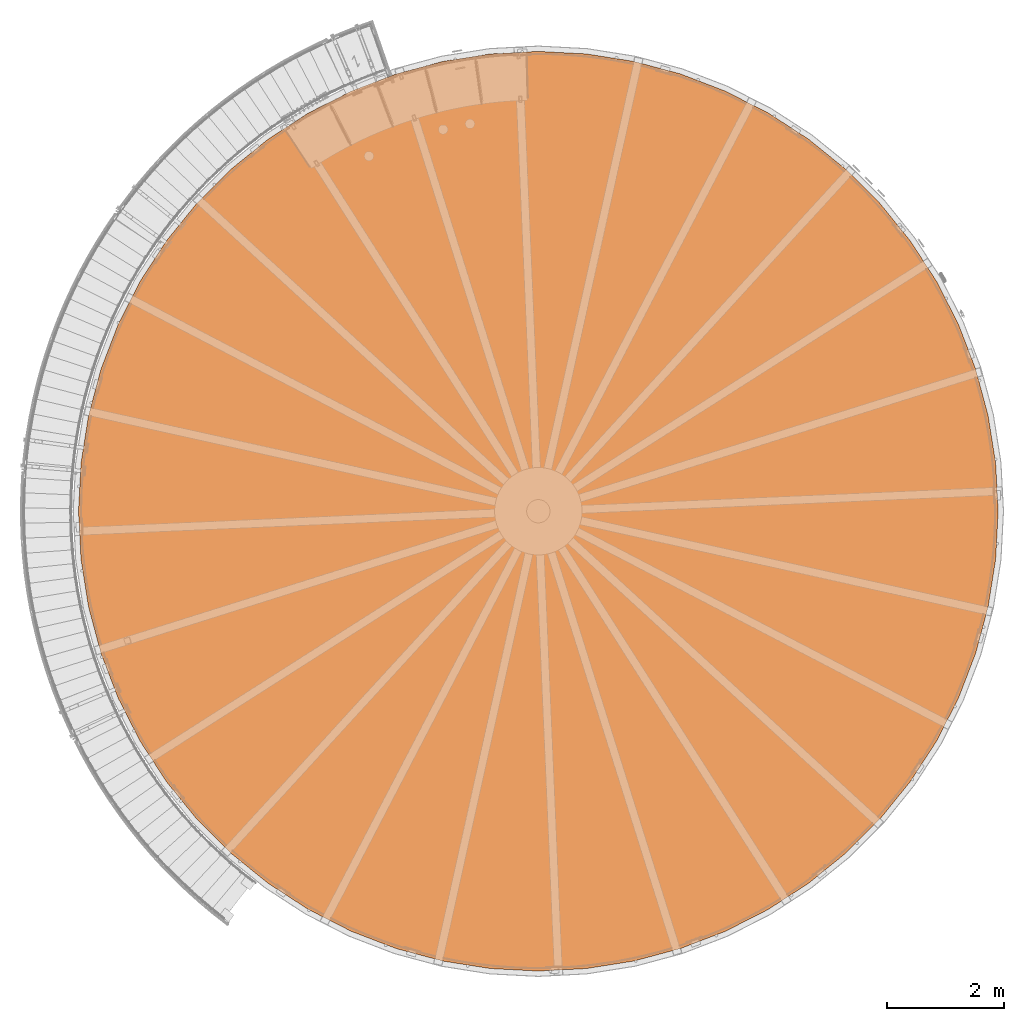
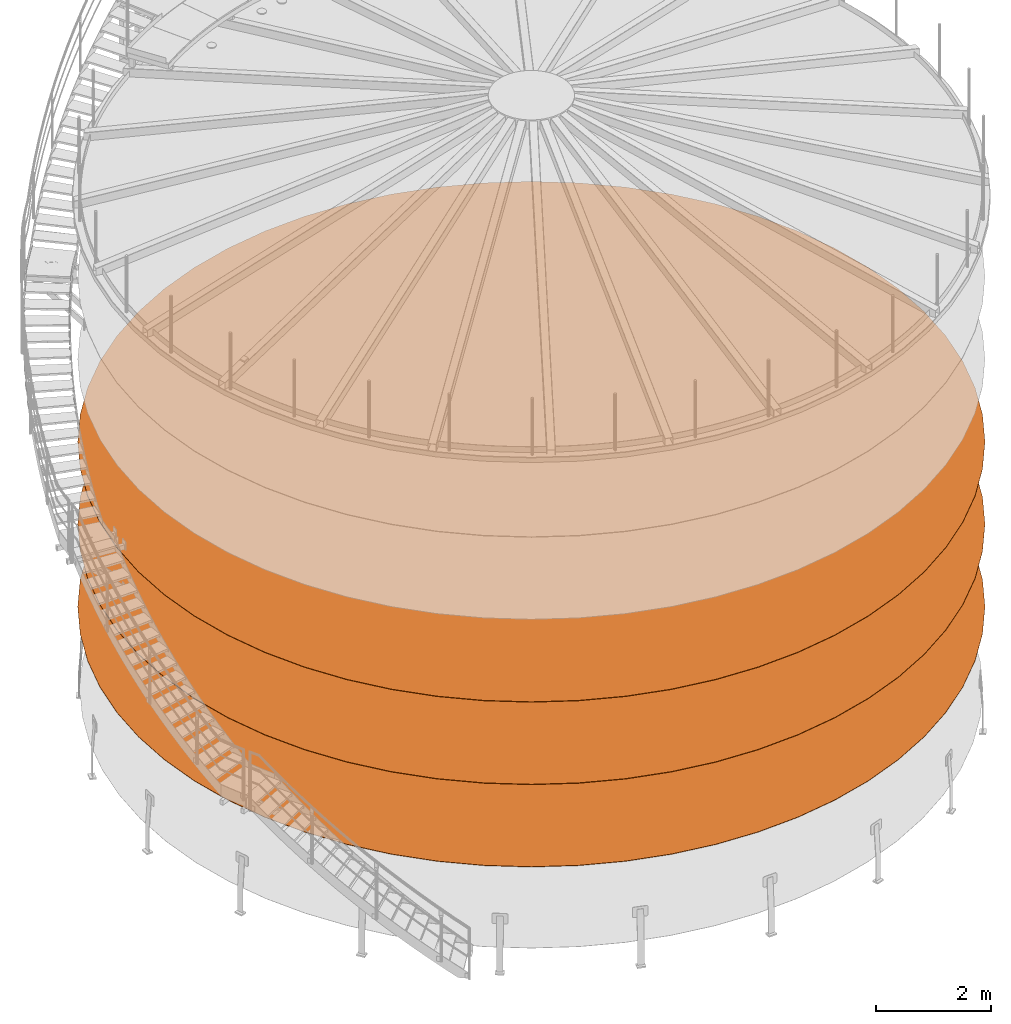
# One storey, part 20 of 126: 3 proxies.
"""IFC2X3 building model written with IfcOpenShell, lengths in millimetres."""

from ifc_helpers import new_model, si_unit, origin, origin_with_axes, place, context, project, spatial, faceted_brep, material, element, save


model = new_model("IFC2X3")

# Units and contexts
context_of_model_1 = context(None, 3, precision=0.1, world=origin())
context_of_model_2 = context(None, 3, precision=0.1, world=origin())
ifc_project = project(units=[si_unit("LENGTHUNIT", "METRE", prefix="MILLI"), si_unit("AREAUNIT", "SQUARE_METRE", prefix="CENTI"), si_unit("VOLUMEUNIT", "CUBIC_METRE", prefix="CENTI"), si_unit("MASSUNIT", "GRAM", prefix="KILO")], contexts=[context_of_model_1, context_of_model_2])

# Site, building, storey
site_placement = place(None, origin_with_axes())
site = spatial("IfcSite", under=ifc_project, at=site_placement, CompositionType="ELEMENT")
building_placement = place(site_placement, origin_with_axes())
building = spatial("IfcBuilding", under=site, at=building_placement, CompositionType="ELEMENT")
storey_placement = place(building_placement, origin_with_axes())
storey = spatial("IfcBuildingStorey", under=building, at=storey_placement, CompositionType="ELEMENT")

# Proxies
ifc_material = material(Name="STAHL")
proxy_1_placement = place(storey_placement, origin_with_axes())
element("IfcBuildingElementProxy", 1, at=proxy_1_placement, inside=storey, material=ifc_material, Name="profile", context=context_of_model_2, shape_type="Brep", body=[
    faceted_brep([(4062.5, 14833.6, 5256.0), (4797.9, 15208.3, 5256.0), (4797.9, 15208.3, 5248.0), (4062.5, 14833.6, 5248.0), (15890.0, 8005.0, 5256.0), (15890.0, 8005.0, 5248.0), (15846.8, 8829.2, 5248.0), (15846.8, 8829.2, 5256.0), (3370.3, 14384.1, 5256.0), (3370.3, 14384.1, 5248.0), (15717.7, 9644.4, 5248.0), (15717.7, 9644.4, 5256.0), (2728.9, 13864.7, 5256.0), (2728.9, 13864.7, 5248.0), (2145.3, 13281.1, 5256.0), (2145.3, 13281.1, 5248.0), (15504.1, 10441.6, 5256.0), (15504.1, 10441.6, 5248.0), (1625.9, 12639.7, 5256.0), (1625.9, 12639.7, 5248.0), (15208.3, 11212.1, 5256.0), (15208.3, 11212.1, 5248.0), (1176.4, 11947.5, 5256.0), (1176.4, 11947.5, 5248.0), (14833.6, 11947.5, 5256.0), (14833.6, 11947.5, 5248.0), (801.7, 11212.1, 5256.0), (801.7, 11212.1, 5248.0), (14384.1, 12639.7, 5256.0), (14384.1, 12639.7, 5248.0), (505.9, 10441.6, 5256.0), (505.9, 10441.6, 5248.0), (13864.7, 13281.1, 5256.0), (13864.7, 13281.1, 5248.0), (292.3, 9644.4, 5256.0), (292.3, 9644.4, 5248.0), (13281.1, 13864.7, 5256.0), (13281.1, 13864.7, 5248.0), (163.2, 8829.2, 5256.0), (163.2, 8829.2, 5248.0), (12639.7, 14384.1, 5256.0), (12639.7, 14384.1, 5248.0), (120.0, 8005.0, 5256.0), (120.0, 8005.0, 5248.0), (11947.5, 14833.6, 5256.0), (11947.5, 14833.6, 5248.0), (11212.1, 15208.3, 5256.0), (11212.1, 15208.3, 5248.0), (10441.6, 15504.1, 5256.0), (10441.6, 15504.1, 5248.0), (9644.4, 15717.7, 5256.0), (9644.4, 15717.7, 5248.0), (8829.2, 15846.8, 5256.0), (8829.2, 15846.8, 5248.0), (8005.0, 15890.0, 5256.0), (8005.0, 15890.0, 5248.0), (7180.8, 15846.8, 5256.0), (7180.8, 15846.8, 5248.0), (6365.6, 15717.7, 5256.0), (6365.6, 15717.7, 5248.0), (5568.4, 15504.1, 5256.0), (5568.4, 15504.1, 5248.0), (11179.6, 874.8, 5256.0), (11179.6, 874.8, 5248.0), (10416.9, 582.0, 5248.0), (10416.9, 582.0, 5256.0), (11907.5, 1245.7, 5256.0), (11907.5, 1245.7, 5248.0), (200.0, 8005.0, 5256.0), (242.8, 7189.2, 5256.0), (242.8, 7189.2, 5248.0), (200.0, 8005.0, 5248.0), (12592.7, 1690.6, 5256.0), (12592.7, 1690.6, 5248.0), (13227.6, 2204.8, 5256.0), (13227.6, 2204.8, 5248.0), (370.6, 6382.2, 5256.0), (370.6, 6382.2, 5248.0), (13805.2, 2782.4, 5256.0), (13805.2, 2782.4, 5248.0), (582.0, 5593.1, 5256.0), (582.0, 5593.1, 5248.0), (14319.4, 3417.3, 5256.0), (14319.4, 3417.3, 5248.0), (874.8, 4830.4, 5256.0), (874.8, 4830.4, 5248.0), (14764.3, 4102.5, 5256.0), (14764.3, 4102.5, 5248.0), (1245.7, 4102.5, 5256.0), (1245.7, 4102.5, 5248.0), (15135.2, 4830.4, 5256.0), (15135.2, 4830.4, 5248.0), (1690.6, 3417.3, 5256.0), (1690.6, 3417.3, 5248.0), (15428.0, 5593.1, 5256.0), (15428.0, 5593.1, 5248.0), (2204.8, 2782.4, 5256.0), (2204.8, 2782.4, 5248.0), (15639.4, 6382.2, 5256.0), (15639.4, 6382.2, 5248.0), (2782.4, 2204.8, 5256.0), (2782.4, 2204.8, 5248.0), (15767.2, 7189.2, 5256.0), (15767.2, 7189.2, 5248.0), (3417.3, 1690.6, 5256.0), (3417.3, 1690.6, 5248.0), (15810.0, 8005.0, 5256.0), (15810.0, 8005.0, 5248.0), (4102.5, 1245.7, 5256.0), (4102.5, 1245.7, 5248.0), (4830.4, 874.8, 5256.0), (4830.4, 874.8, 5248.0), (5593.1, 582.0, 5256.0), (5593.1, 582.0, 5248.0), (6382.2, 370.6, 5256.0), (6382.2, 370.6, 5248.0), (7189.2, 242.8, 5256.0), (7189.2, 242.8, 5248.0), (8005.0, 200.0, 5256.0), (8005.0, 200.0, 5248.0), (8820.8, 242.8, 5256.0), (8820.8, 242.8, 5248.0), (9627.8, 370.6, 5256.0), (9627.8, 370.6, 5248.0), (8005.0, 120.0, 5256.0), (8829.2, 163.2, 5256.0), (9644.4, 292.3, 5256.0), (10441.6, 505.9, 5256.0), (11212.1, 801.7, 5256.0), (11947.5, 1176.4, 5256.0), (12639.7, 1625.9, 5256.0), (13281.1, 2145.3, 5256.0), (13864.7, 2728.9, 5256.0), (14384.1, 3370.3, 5256.0), (14833.6, 4062.5, 5256.0), (15208.3, 4797.9, 5256.0), (15504.1, 5568.4, 5256.0), (15717.7, 6365.6, 5256.0), (15846.8, 7180.8, 5256.0), (163.2, 7180.8, 5256.0), (292.3, 6365.6, 5256.0), (505.9, 5568.4, 5256.0), (801.7, 4797.9, 5256.0), (1176.4, 4062.5, 5256.0), (1625.9, 3370.3, 5256.0), (2145.3, 2728.9, 5256.0), (2728.9, 2145.3, 5256.0), (242.8, 8820.8, 5256.0), (370.6, 9627.8, 5256.0), (582.0, 10416.9, 5256.0), (874.8, 11179.6, 5256.0), (1245.7, 11907.5, 5256.0), (1690.6, 12592.7, 5256.0), (2204.8, 13227.6, 5256.0), (2782.4, 13805.2, 5256.0), (3417.3, 14319.4, 5256.0), (4102.5, 14764.3, 5256.0), (4830.4, 15135.2, 5256.0), (5593.1, 15428.0, 5256.0), (6382.2, 15639.4, 5256.0), (7189.2, 15767.2, 5256.0), (8005.0, 15810.0, 5256.0), (8820.8, 15767.2, 5256.0), (9627.8, 15639.4, 5256.0), (10416.9, 15428.0, 5256.0), (11179.6, 15135.2, 5256.0), (11907.5, 14764.3, 5256.0), (12592.7, 14319.4, 5256.0), (13227.6, 13805.2, 5256.0), (13805.2, 13227.6, 5256.0), (14319.4, 12592.7, 5256.0), (14764.3, 11907.5, 5256.0), (15135.2, 11179.6, 5256.0), (15428.0, 10416.9, 5256.0), (15639.4, 9627.8, 5256.0), (15767.2, 8820.8, 5256.0), (3370.3, 1625.9, 5256.0), (4062.5, 1176.4, 5256.0), (4797.9, 801.7, 5256.0), (5568.4, 505.9, 5256.0), (6365.6, 292.3, 5256.0), (7180.8, 163.2, 5256.0), (4830.4, 15135.2, 5248.0), (5593.1, 15428.0, 5248.0), (4102.5, 14764.3, 5248.0), (3417.3, 14319.4, 5248.0), (15767.2, 8820.8, 5248.0), (2782.4, 13805.2, 5248.0), (15639.4, 9627.8, 5248.0), (2204.8, 13227.6, 5248.0), (15428.0, 10416.9, 5248.0), (1690.6, 12592.7, 5248.0), (15135.2, 11179.6, 5248.0), (1245.7, 11907.5, 5248.0), (14764.3, 11907.5, 5248.0), (874.8, 11179.6, 5248.0), (14319.4, 12592.7, 5248.0), (582.0, 10416.9, 5248.0), (13805.2, 13227.6, 5248.0), (370.6, 9627.8, 5248.0), (13227.6, 13805.2, 5248.0), (242.8, 8820.8, 5248.0), (12592.7, 14319.4, 5248.0), (11907.5, 14764.3, 5248.0), (11179.6, 15135.2, 5248.0), (10416.9, 15428.0, 5248.0), (9627.8, 15639.4, 5248.0), (8820.8, 15767.2, 5248.0), (8005.0, 15810.0, 5248.0), (7189.2, 15767.2, 5248.0), (6382.2, 15639.4, 5248.0), (8005.0, 120.0, 5248.0), (7180.8, 163.2, 5248.0), (6365.6, 292.3, 5248.0), (5568.4, 505.9, 5248.0), (4797.9, 801.7, 5248.0), (4062.5, 1176.4, 5248.0), (3370.3, 1625.9, 5248.0), (2728.9, 2145.3, 5248.0), (2145.3, 2728.9, 5248.0), (1625.9, 3370.3, 5248.0), (1176.4, 4062.5, 5248.0), (801.7, 4797.9, 5248.0), (505.9, 5568.4, 5248.0), (292.3, 6365.6, 5248.0), (163.2, 7180.8, 5248.0), (15846.8, 7180.8, 5248.0), (15717.7, 6365.6, 5248.0), (15504.1, 5568.4, 5248.0), (15208.3, 4797.9, 5248.0), (14833.6, 4062.5, 5248.0), (14384.1, 3370.3, 5248.0), (13864.7, 2728.9, 5248.0), (13281.1, 2145.3, 5248.0), (12639.7, 1625.9, 5248.0), (11947.5, 1176.4, 5248.0), (11212.1, 801.7, 5248.0), (10441.6, 505.9, 5248.0), (9644.4, 292.3, 5248.0), (8829.2, 163.2, 5248.0)], [[[0, 1, 2, 3]], [[4, 5, 6, 7]], [[8, 0, 3, 9]], [[7, 6, 10, 11]], [[12, 8, 9, 13]], [[14, 12, 13, 15]], [[16, 11, 10, 17]], [[18, 14, 15, 19]], [[20, 16, 17, 21]], [[22, 18, 19, 23]], [[24, 20, 21, 25]], [[26, 22, 23, 27]], [[28, 24, 25, 29]], [[30, 26, 27, 31]], [[32, 28, 29, 33]], [[34, 30, 31, 35]], [[36, 32, 33, 37]], [[38, 34, 35, 39]], [[40, 36, 37, 41]], [[42, 38, 39, 43]], [[44, 40, 41, 45]], [[46, 44, 45, 47]], [[48, 46, 47, 49]], [[50, 48, 49, 51]], [[52, 50, 51, 53]], [[54, 52, 53, 55]], [[56, 54, 55, 57]], [[58, 56, 57, 59]], [[60, 58, 59, 61]], [[1, 60, 61, 2]], [[62, 63, 64, 65]], [[66, 67, 63, 62]], [[68, 69, 70, 71]], [[72, 73, 67, 66]], [[74, 75, 73, 72]], [[76, 77, 70, 69]], [[78, 79, 75, 74]], [[80, 81, 77, 76]], [[82, 83, 79, 78]], [[84, 85, 81, 80]], [[86, 87, 83, 82]], [[88, 89, 85, 84]], [[90, 91, 87, 86]], [[92, 93, 89, 88]], [[94, 95, 91, 90]], [[96, 97, 93, 92]], [[98, 99, 95, 94]], [[100, 101, 97, 96]], [[102, 103, 99, 98]], [[104, 105, 101, 100]], [[106, 107, 103, 102]], [[108, 109, 105, 104]], [[110, 111, 109, 108]], [[112, 113, 111, 110]], [[114, 115, 113, 112]], [[116, 117, 115, 114]], [[118, 119, 117, 116]], [[120, 121, 119, 118]], [[122, 123, 121, 120]], [[65, 64, 123, 122]], [[124, 125, 126, 127, 128, 129, 130, 131, 132, 133, 134, 135, 136, 137, 138, 4, 7, 11, 16, 20, 24, 28, 32, 36, 40, 44, 46, 48, 50, 52, 54, 56, 58, 60, 1, 0, 8, 12, 14, 18, 22, 26, 30, 34, 38, 42, 139, 140, 141, 142, 143, 144, 145, 146, 96, 92, 88, 84, 80, 76, 69, 68, 147, 148, 149, 150, 151, 152, 153, 154, 155, 156, 157, 158, 159, 160, 161, 162, 163, 164, 165, 166, 167, 168, 169, 170, 171, 172, 173, 174, 175, 106, 102, 98, 94, 90, 86, 82, 78, 74, 72, 66, 62, 65, 122, 120, 118, 116, 114, 112, 110, 108, 104, 100, 96, 146, 176, 177, 178, 179, 180, 181]], [[157, 182, 183, 158]], [[156, 184, 182, 157]], [[155, 185, 184, 156]], [[175, 186, 107, 106]], [[154, 187, 185, 155]], [[174, 188, 186, 175]], [[153, 189, 187, 154]], [[173, 190, 188, 174]], [[152, 191, 189, 153]], [[172, 192, 190, 173]], [[151, 193, 191, 152]], [[171, 194, 192, 172]], [[150, 195, 193, 151]], [[170, 196, 194, 171]], [[149, 197, 195, 150]], [[169, 198, 196, 170]], [[148, 199, 197, 149]], [[168, 200, 198, 169]], [[147, 201, 199, 148]], [[167, 202, 200, 168]], [[68, 71, 201, 147]], [[166, 203, 202, 167]], [[165, 204, 203, 166]], [[164, 205, 204, 165]], [[163, 206, 205, 164]], [[162, 207, 206, 163]], [[161, 208, 207, 162]], [[160, 209, 208, 161]], [[159, 210, 209, 160]], [[158, 183, 210, 159]], [[211, 212, 213, 214, 215, 216, 217, 218, 219, 220, 221, 222, 223, 224, 225, 43, 39, 35, 31, 27, 23, 19, 15, 13, 9, 3, 2, 61, 59, 57, 55, 53, 51, 49, 47, 45, 41, 37, 33, 29, 25, 21, 17, 10, 6, 5, 226, 227, 228, 229, 230, 231, 232, 75, 79, 83, 87, 91, 95, 99, 103, 107, 186, 188, 190, 192, 194, 196, 198, 200, 202, 203, 204, 205, 206, 207, 208, 209, 210, 183, 182, 184, 185, 187, 189, 191, 193, 195, 197, 199, 201, 71, 70, 77, 81, 85, 89, 93, 97, 101, 105, 109, 111, 113, 115, 117, 119, 121, 123, 64, 63, 67, 73, 75, 232, 233, 234, 235, 236, 237, 238, 239]], [[128, 127, 237, 236]], [[129, 128, 236, 235]], [[130, 129, 235, 234]], [[139, 42, 43, 225]], [[131, 130, 234, 233]], [[140, 139, 225, 224]], [[140, 224, 223, 141]], [[132, 131, 233, 232]], [[133, 132, 232, 231]], [[142, 141, 223, 222]], [[134, 133, 231, 230]], [[143, 142, 222, 221]], [[135, 134, 230, 229]], [[144, 143, 221, 220]], [[136, 135, 229, 228]], [[145, 144, 220, 219]], [[137, 136, 228, 227]], [[146, 145, 219, 218]], [[138, 137, 227, 226]], [[176, 146, 218, 217]], [[4, 138, 226, 5]], [[177, 176, 217, 216]], [[178, 177, 216, 215]], [[179, 178, 215, 214]], [[180, 179, 214, 213]], [[181, 180, 213, 212]], [[124, 181, 212, 211]], [[125, 124, 211, 239]], [[126, 125, 239, 238]], [[127, 126, 238, 237]]]),
])
proxy_2_placement = place(storey_placement, origin_with_axes())
element("IfcBuildingElementProxy", 2, at=proxy_2_placement, inside=storey, material=ifc_material, Name="profile", context=context_of_model_2, shape_type="Brep", body=[
    faceted_brep([(4062.5, 14833.6, 3506.0), (4797.9, 15208.3, 3506.0), (4797.9, 15208.3, 3498.0), (4062.5, 14833.6, 3498.0), (15890.0, 8005.0, 3506.0), (15890.0, 8005.0, 3498.0), (15846.8, 8829.2, 3498.0), (15846.8, 8829.2, 3506.0), (3370.3, 14384.1, 3506.0), (3370.3, 14384.1, 3498.0), (15717.7, 9644.4, 3498.0), (15717.7, 9644.4, 3506.0), (2728.9, 13864.7, 3506.0), (2728.9, 13864.7, 3498.0), (2145.3, 13281.1, 3506.0), (2145.3, 13281.1, 3498.0), (15504.1, 10441.6, 3506.0), (15504.1, 10441.6, 3498.0), (1625.9, 12639.7, 3506.0), (1625.9, 12639.7, 3498.0), (15208.3, 11212.1, 3506.0), (15208.3, 11212.1, 3498.0), (1176.4, 11947.5, 3506.0), (1176.4, 11947.5, 3498.0), (14833.6, 11947.5, 3506.0), (14833.6, 11947.5, 3498.0), (801.7, 11212.1, 3506.0), (801.7, 11212.1, 3498.0), (14384.1, 12639.7, 3506.0), (14384.1, 12639.7, 3498.0), (505.9, 10441.6, 3506.0), (505.9, 10441.6, 3498.0), (13864.7, 13281.1, 3506.0), (13864.7, 13281.1, 3498.0), (292.3, 9644.4, 3506.0), (292.3, 9644.4, 3498.0), (13281.1, 13864.7, 3506.0), (13281.1, 13864.7, 3498.0), (163.2, 8829.2, 3506.0), (163.2, 8829.2, 3498.0), (12639.7, 14384.1, 3506.0), (12639.7, 14384.1, 3498.0), (120.0, 8005.0, 3506.0), (120.0, 8005.0, 3498.0), (11947.5, 14833.6, 3506.0), (11947.5, 14833.6, 3498.0), (11212.1, 15208.3, 3506.0), (11212.1, 15208.3, 3498.0), (10441.6, 15504.1, 3506.0), (10441.6, 15504.1, 3498.0), (9644.4, 15717.7, 3506.0), (9644.4, 15717.7, 3498.0), (8829.2, 15846.8, 3506.0), (8829.2, 15846.8, 3498.0), (8005.0, 15890.0, 3506.0), (8005.0, 15890.0, 3498.0), (7180.8, 15846.8, 3506.0), (7180.8, 15846.8, 3498.0), (6365.6, 15717.7, 3506.0), (6365.6, 15717.7, 3498.0), (5568.4, 15504.1, 3506.0), (5568.4, 15504.1, 3498.0), (11179.6, 874.8, 3506.0), (11179.6, 874.8, 3498.0), (10416.9, 582.0, 3498.0), (10416.9, 582.0, 3506.0), (11907.5, 1245.7, 3506.0), (11907.5, 1245.7, 3498.0), (200.0, 8005.0, 3506.0), (242.8, 7189.2, 3506.0), (242.8, 7189.2, 3498.0), (200.0, 8005.0, 3498.0), (12592.7, 1690.6, 3506.0), (12592.7, 1690.6, 3498.0), (13227.6, 2204.8, 3506.0), (13227.6, 2204.8, 3498.0), (370.6, 6382.2, 3506.0), (370.6, 6382.2, 3498.0), (13805.2, 2782.4, 3506.0), (13805.2, 2782.4, 3498.0), (582.0, 5593.1, 3506.0), (582.0, 5593.1, 3498.0), (14319.4, 3417.3, 3506.0), (14319.4, 3417.3, 3498.0), (874.8, 4830.4, 3506.0), (874.8, 4830.4, 3498.0), (14764.3, 4102.5, 3506.0), (14764.3, 4102.5, 3498.0), (1245.7, 4102.5, 3506.0), (1245.7, 4102.5, 3498.0), (15135.2, 4830.4, 3506.0), (15135.2, 4830.4, 3498.0), (1690.6, 3417.3, 3506.0), (1690.6, 3417.3, 3498.0), (15428.0, 5593.1, 3506.0), (15428.0, 5593.1, 3498.0), (2204.8, 2782.4, 3506.0), (2204.8, 2782.4, 3498.0), (15639.4, 6382.2, 3506.0), (15639.4, 6382.2, 3498.0), (2782.4, 2204.8, 3506.0), (2782.4, 2204.8, 3498.0), (15767.2, 7189.2, 3506.0), (15767.2, 7189.2, 3498.0), (3417.3, 1690.6, 3506.0), (3417.3, 1690.6, 3498.0), (15810.0, 8005.0, 3506.0), (15810.0, 8005.0, 3498.0), (4102.5, 1245.7, 3506.0), (4102.5, 1245.7, 3498.0), (4830.4, 874.8, 3506.0), (4830.4, 874.8, 3498.0), (5593.1, 582.0, 3506.0), (5593.1, 582.0, 3498.0), (6382.2, 370.6, 3506.0), (6382.2, 370.6, 3498.0), (7189.2, 242.8, 3506.0), (7189.2, 242.8, 3498.0), (8005.0, 200.0, 3506.0), (8005.0, 200.0, 3498.0), (8820.8, 242.8, 3506.0), (8820.8, 242.8, 3498.0), (9627.8, 370.6, 3506.0), (9627.8, 370.6, 3498.0), (8005.0, 120.0, 3506.0), (8829.2, 163.2, 3506.0), (9644.4, 292.3, 3506.0), (10441.6, 505.9, 3506.0), (11212.1, 801.7, 3506.0), (11947.5, 1176.4, 3506.0), (12639.7, 1625.9, 3506.0), (13281.1, 2145.3, 3506.0), (13864.7, 2728.9, 3506.0), (14384.1, 3370.3, 3506.0), (14833.6, 4062.5, 3506.0), (15208.3, 4797.9, 3506.0), (15504.1, 5568.4, 3506.0), (15717.7, 6365.6, 3506.0), (15846.8, 7180.8, 3506.0), (163.2, 7180.8, 3506.0), (292.3, 6365.6, 3506.0), (505.9, 5568.4, 3506.0), (801.7, 4797.9, 3506.0), (1176.4, 4062.5, 3506.0), (1625.9, 3370.3, 3506.0), (2145.3, 2728.9, 3506.0), (2728.9, 2145.3, 3506.0), (242.8, 8820.8, 3506.0), (370.6, 9627.8, 3506.0), (582.0, 10416.9, 3506.0), (874.8, 11179.6, 3506.0), (1245.7, 11907.5, 3506.0), (1690.6, 12592.7, 3506.0), (2204.8, 13227.6, 3506.0), (2782.4, 13805.2, 3506.0), (3417.3, 14319.4, 3506.0), (4102.5, 14764.3, 3506.0), (4830.4, 15135.2, 3506.0), (5593.1, 15428.0, 3506.0), (6382.2, 15639.4, 3506.0), (7189.2, 15767.2, 3506.0), (8005.0, 15810.0, 3506.0), (8820.8, 15767.2, 3506.0), (9627.8, 15639.4, 3506.0), (10416.9, 15428.0, 3506.0), (11179.6, 15135.2, 3506.0), (11907.5, 14764.3, 3506.0), (12592.7, 14319.4, 3506.0), (13227.6, 13805.2, 3506.0), (13805.2, 13227.6, 3506.0), (14319.4, 12592.7, 3506.0), (14764.3, 11907.5, 3506.0), (15135.2, 11179.6, 3506.0), (15428.0, 10416.9, 3506.0), (15639.4, 9627.8, 3506.0), (15767.2, 8820.8, 3506.0), (3370.3, 1625.9, 3506.0), (4062.5, 1176.4, 3506.0), (4797.9, 801.7, 3506.0), (5568.4, 505.9, 3506.0), (6365.6, 292.3, 3506.0), (7180.8, 163.2, 3506.0), (4830.4, 15135.2, 3498.0), (5593.1, 15428.0, 3498.0), (4102.5, 14764.3, 3498.0), (3417.3, 14319.4, 3498.0), (15767.2, 8820.8, 3498.0), (2782.4, 13805.2, 3498.0), (15639.4, 9627.8, 3498.0), (2204.8, 13227.6, 3498.0), (15428.0, 10416.9, 3498.0), (1690.6, 12592.7, 3498.0), (15135.2, 11179.6, 3498.0), (1245.7, 11907.5, 3498.0), (14764.3, 11907.5, 3498.0), (874.8, 11179.6, 3498.0), (14319.4, 12592.7, 3498.0), (582.0, 10416.9, 3498.0), (13805.2, 13227.6, 3498.0), (370.6, 9627.8, 3498.0), (13227.6, 13805.2, 3498.0), (242.8, 8820.8, 3498.0), (12592.7, 14319.4, 3498.0), (11907.5, 14764.3, 3498.0), (11179.6, 15135.2, 3498.0), (10416.9, 15428.0, 3498.0), (9627.8, 15639.4, 3498.0), (8820.8, 15767.2, 3498.0), (8005.0, 15810.0, 3498.0), (7189.2, 15767.2, 3498.0), (6382.2, 15639.4, 3498.0), (8005.0, 120.0, 3498.0), (7180.8, 163.2, 3498.0), (6365.6, 292.3, 3498.0), (5568.4, 505.9, 3498.0), (4797.9, 801.7, 3498.0), (4062.5, 1176.4, 3498.0), (3370.3, 1625.9, 3498.0), (2728.9, 2145.3, 3498.0), (2145.3, 2728.9, 3498.0), (1625.9, 3370.3, 3498.0), (1176.4, 4062.5, 3498.0), (801.7, 4797.9, 3498.0), (505.9, 5568.4, 3498.0), (292.3, 6365.6, 3498.0), (163.2, 7180.8, 3498.0), (15846.8, 7180.8, 3498.0), (15717.7, 6365.6, 3498.0), (15504.1, 5568.4, 3498.0), (15208.3, 4797.9, 3498.0), (14833.6, 4062.5, 3498.0), (14384.1, 3370.3, 3498.0), (13864.7, 2728.9, 3498.0), (13281.1, 2145.3, 3498.0), (12639.7, 1625.9, 3498.0), (11947.5, 1176.4, 3498.0), (11212.1, 801.7, 3498.0), (10441.6, 505.9, 3498.0), (9644.4, 292.3, 3498.0), (8829.2, 163.2, 3498.0)], [[[0, 1, 2, 3]], [[4, 5, 6, 7]], [[8, 0, 3, 9]], [[7, 6, 10, 11]], [[12, 8, 9, 13]], [[14, 12, 13, 15]], [[16, 11, 10, 17]], [[18, 14, 15, 19]], [[20, 16, 17, 21]], [[22, 18, 19, 23]], [[24, 20, 21, 25]], [[26, 22, 23, 27]], [[28, 24, 25, 29]], [[30, 26, 27, 31]], [[32, 28, 29, 33]], [[34, 30, 31, 35]], [[36, 32, 33, 37]], [[38, 34, 35, 39]], [[40, 36, 37, 41]], [[42, 38, 39, 43]], [[44, 40, 41, 45]], [[46, 44, 45, 47]], [[48, 46, 47, 49]], [[50, 48, 49, 51]], [[52, 50, 51, 53]], [[54, 52, 53, 55]], [[56, 54, 55, 57]], [[58, 56, 57, 59]], [[60, 58, 59, 61]], [[1, 60, 61, 2]], [[62, 63, 64, 65]], [[66, 67, 63, 62]], [[68, 69, 70, 71]], [[72, 73, 67, 66]], [[74, 75, 73, 72]], [[76, 77, 70, 69]], [[78, 79, 75, 74]], [[80, 81, 77, 76]], [[82, 83, 79, 78]], [[84, 85, 81, 80]], [[86, 87, 83, 82]], [[88, 89, 85, 84]], [[90, 91, 87, 86]], [[92, 93, 89, 88]], [[94, 95, 91, 90]], [[96, 97, 93, 92]], [[98, 99, 95, 94]], [[100, 101, 97, 96]], [[102, 103, 99, 98]], [[104, 105, 101, 100]], [[106, 107, 103, 102]], [[108, 109, 105, 104]], [[110, 111, 109, 108]], [[112, 113, 111, 110]], [[114, 115, 113, 112]], [[116, 117, 115, 114]], [[118, 119, 117, 116]], [[120, 121, 119, 118]], [[122, 123, 121, 120]], [[65, 64, 123, 122]], [[124, 125, 126, 127, 128, 129, 130, 131, 132, 133, 134, 135, 136, 137, 138, 4, 7, 11, 16, 20, 24, 28, 32, 36, 40, 44, 46, 48, 50, 52, 54, 56, 58, 60, 1, 0, 8, 12, 14, 18, 22, 26, 30, 34, 38, 42, 139, 140, 141, 142, 143, 144, 145, 146, 96, 92, 88, 84, 80, 76, 69, 68, 147, 148, 149, 150, 151, 152, 153, 154, 155, 156, 157, 158, 159, 160, 161, 162, 163, 164, 165, 166, 167, 168, 169, 170, 171, 172, 173, 174, 175, 106, 102, 98, 94, 90, 86, 82, 78, 74, 72, 66, 62, 65, 122, 120, 118, 116, 114, 112, 110, 108, 104, 100, 96, 146, 176, 177, 178, 179, 180, 181]], [[157, 182, 183, 158]], [[156, 184, 182, 157]], [[155, 185, 184, 156]], [[175, 186, 107, 106]], [[154, 187, 185, 155]], [[174, 188, 186, 175]], [[153, 189, 187, 154]], [[173, 190, 188, 174]], [[152, 191, 189, 153]], [[172, 192, 190, 173]], [[151, 193, 191, 152]], [[171, 194, 192, 172]], [[150, 195, 193, 151]], [[170, 196, 194, 171]], [[149, 197, 195, 150]], [[169, 198, 196, 170]], [[148, 199, 197, 149]], [[168, 200, 198, 169]], [[147, 201, 199, 148]], [[167, 202, 200, 168]], [[68, 71, 201, 147]], [[166, 203, 202, 167]], [[165, 204, 203, 166]], [[164, 205, 204, 165]], [[163, 206, 205, 164]], [[162, 207, 206, 163]], [[161, 208, 207, 162]], [[160, 209, 208, 161]], [[159, 210, 209, 160]], [[158, 183, 210, 159]], [[211, 212, 213, 214, 215, 216, 217, 218, 219, 220, 221, 222, 223, 224, 225, 43, 39, 35, 31, 27, 23, 19, 15, 13, 9, 3, 2, 61, 59, 57, 55, 53, 51, 49, 47, 45, 41, 37, 33, 29, 25, 21, 17, 10, 6, 5, 226, 227, 228, 229, 230, 231, 232, 75, 79, 83, 87, 91, 95, 99, 103, 107, 186, 188, 190, 192, 194, 196, 198, 200, 202, 203, 204, 205, 206, 207, 208, 209, 210, 183, 182, 184, 185, 187, 189, 191, 193, 195, 197, 199, 201, 71, 70, 77, 81, 85, 89, 93, 97, 101, 105, 109, 111, 113, 115, 117, 119, 121, 123, 64, 63, 67, 73, 75, 232, 233, 234, 235, 236, 237, 238, 239]], [[128, 127, 237, 236]], [[129, 128, 236, 235]], [[130, 129, 235, 234]], [[139, 42, 43, 225]], [[131, 130, 234, 233]], [[140, 139, 225, 224]], [[140, 224, 223, 141]], [[132, 131, 233, 232]], [[133, 132, 232, 231]], [[142, 141, 223, 222]], [[134, 133, 231, 230]], [[143, 142, 222, 221]], [[135, 134, 230, 229]], [[144, 143, 221, 220]], [[136, 135, 229, 228]], [[145, 144, 220, 219]], [[137, 136, 228, 227]], [[146, 145, 219, 218]], [[138, 137, 227, 226]], [[176, 146, 218, 217]], [[4, 138, 226, 5]], [[177, 176, 217, 216]], [[178, 177, 216, 215]], [[179, 178, 215, 214]], [[180, 179, 214, 213]], [[181, 180, 213, 212]], [[124, 181, 212, 211]], [[125, 124, 211, 239]], [[126, 125, 239, 238]], [[127, 126, 238, 237]]]),
])
proxy_3_placement = place(storey_placement, origin_with_axes())
element("IfcBuildingElementProxy", 3, at=proxy_3_placement, inside=storey, material=ifc_material, Name="profile", context=context_of_model_2, shape_type="Brep", body=[
    faceted_brep([(4062.5, 14833.6, 1756.0), (4797.9, 15208.3, 1756.0), (4797.9, 15208.3, 1748.0), (4062.5, 14833.6, 1748.0), (15890.0, 8005.0, 1756.0), (15890.0, 8005.0, 1748.0), (15846.8, 8829.2, 1748.0), (15846.8, 8829.2, 1756.0), (3370.3, 14384.1, 1756.0), (3370.3, 14384.1, 1748.0), (15717.7, 9644.4, 1748.0), (15717.7, 9644.4, 1756.0), (2728.9, 13864.7, 1756.0), (2728.9, 13864.7, 1748.0), (2145.3, 13281.1, 1756.0), (2145.3, 13281.1, 1748.0), (15504.1, 10441.6, 1756.0), (15504.1, 10441.6, 1748.0), (1625.9, 12639.7, 1756.0), (1625.9, 12639.7, 1748.0), (15208.3, 11212.1, 1756.0), (15208.3, 11212.1, 1748.0), (1176.4, 11947.5, 1756.0), (1176.4, 11947.5, 1748.0), (14833.6, 11947.5, 1756.0), (14833.6, 11947.5, 1748.0), (801.7, 11212.1, 1756.0), (801.7, 11212.1, 1748.0), (14384.1, 12639.7, 1756.0), (14384.1, 12639.7, 1748.0), (505.9, 10441.6, 1756.0), (505.9, 10441.6, 1748.0), (13864.7, 13281.1, 1756.0), (13864.7, 13281.1, 1748.0), (292.3, 9644.4, 1756.0), (292.3, 9644.4, 1748.0), (13281.1, 13864.7, 1756.0), (13281.1, 13864.7, 1748.0), (163.2, 8829.2, 1756.0), (163.2, 8829.2, 1748.0), (12639.7, 14384.1, 1756.0), (12639.7, 14384.1, 1748.0), (120.0, 8005.0, 1756.0), (120.0, 8005.0, 1748.0), (11947.5, 14833.6, 1756.0), (11947.5, 14833.6, 1748.0), (11212.1, 15208.3, 1756.0), (11212.1, 15208.3, 1748.0), (10441.6, 15504.1, 1756.0), (10441.6, 15504.1, 1748.0), (9644.4, 15717.7, 1756.0), (9644.4, 15717.7, 1748.0), (8829.2, 15846.8, 1756.0), (8829.2, 15846.8, 1748.0), (8005.0, 15890.0, 1756.0), (8005.0, 15890.0, 1748.0), (7180.8, 15846.8, 1756.0), (7180.8, 15846.8, 1748.0), (6365.6, 15717.7, 1756.0), (6365.6, 15717.7, 1748.0), (5568.4, 15504.1, 1756.0), (5568.4, 15504.1, 1748.0), (11179.6, 874.8, 1756.0), (11179.6, 874.8, 1748.0), (10416.9, 582.0, 1748.0), (10416.9, 582.0, 1756.0), (11907.5, 1245.7, 1756.0), (11907.5, 1245.7, 1748.0), (200.0, 8005.0, 1756.0), (242.8, 7189.2, 1756.0), (242.8, 7189.2, 1748.0), (200.0, 8005.0, 1748.0), (12592.7, 1690.6, 1756.0), (12592.7, 1690.6, 1748.0), (13227.6, 2204.8, 1756.0), (13227.6, 2204.8, 1748.0), (370.6, 6382.2, 1756.0), (370.6, 6382.2, 1748.0), (13805.2, 2782.4, 1756.0), (13805.2, 2782.4, 1748.0), (582.0, 5593.1, 1756.0), (582.0, 5593.1, 1748.0), (14319.4, 3417.3, 1756.0), (14319.4, 3417.3, 1748.0), (874.8, 4830.4, 1756.0), (874.8, 4830.4, 1748.0), (14764.3, 4102.5, 1756.0), (14764.3, 4102.5, 1748.0), (1245.7, 4102.5, 1756.0), (1245.7, 4102.5, 1748.0), (15135.2, 4830.4, 1756.0), (15135.2, 4830.4, 1748.0), (1690.6, 3417.3, 1756.0), (1690.6, 3417.3, 1748.0), (15428.0, 5593.1, 1756.0), (15428.0, 5593.1, 1748.0), (2204.8, 2782.4, 1756.0), (2204.8, 2782.4, 1748.0), (15639.4, 6382.2, 1756.0), (15639.4, 6382.2, 1748.0), (2782.4, 2204.8, 1756.0), (2782.4, 2204.8, 1748.0), (15767.2, 7189.2, 1756.0), (15767.2, 7189.2, 1748.0), (3417.3, 1690.6, 1756.0), (3417.3, 1690.6, 1748.0), (15810.0, 8005.0, 1756.0), (15810.0, 8005.0, 1748.0), (4102.5, 1245.7, 1756.0), (4102.5, 1245.7, 1748.0), (4830.4, 874.8, 1756.0), (4830.4, 874.8, 1748.0), (5593.1, 582.0, 1756.0), (5593.1, 582.0, 1748.0), (6382.2, 370.6, 1756.0), (6382.2, 370.6, 1748.0), (7189.2, 242.8, 1756.0), (7189.2, 242.8, 1748.0), (8005.0, 200.0, 1756.0), (8005.0, 200.0, 1748.0), (8820.8, 242.8, 1756.0), (8820.8, 242.8, 1748.0), (9627.8, 370.6, 1756.0), (9627.8, 370.6, 1748.0), (8005.0, 120.0, 1756.0), (8829.2, 163.2, 1756.0), (9644.4, 292.3, 1756.0), (10441.6, 505.9, 1756.0), (11212.1, 801.7, 1756.0), (11947.5, 1176.4, 1756.0), (12639.7, 1625.9, 1756.0), (13281.1, 2145.3, 1756.0), (13864.7, 2728.9, 1756.0), (14384.1, 3370.3, 1756.0), (14833.6, 4062.5, 1756.0), (15208.3, 4797.9, 1756.0), (15504.1, 5568.4, 1756.0), (15717.7, 6365.6, 1756.0), (15846.8, 7180.8, 1756.0), (163.2, 7180.8, 1756.0), (292.3, 6365.6, 1756.0), (505.9, 5568.4, 1756.0), (801.7, 4797.9, 1756.0), (1176.4, 4062.5, 1756.0), (1625.9, 3370.3, 1756.0), (2145.3, 2728.9, 1756.0), (2728.9, 2145.3, 1756.0), (242.8, 8820.8, 1756.0), (370.6, 9627.8, 1756.0), (582.0, 10416.9, 1756.0), (874.8, 11179.6, 1756.0), (1245.7, 11907.5, 1756.0), (1690.6, 12592.7, 1756.0), (2204.8, 13227.6, 1756.0), (2782.4, 13805.2, 1756.0), (3417.3, 14319.4, 1756.0), (4102.5, 14764.3, 1756.0), (4830.4, 15135.2, 1756.0), (5593.1, 15428.0, 1756.0), (6382.2, 15639.4, 1756.0), (7189.2, 15767.2, 1756.0), (8005.0, 15810.0, 1756.0), (8820.8, 15767.2, 1756.0), (9627.8, 15639.4, 1756.0), (10416.9, 15428.0, 1756.0), (11179.6, 15135.2, 1756.0), (11907.5, 14764.3, 1756.0), (12592.7, 14319.4, 1756.0), (13227.6, 13805.2, 1756.0), (13805.2, 13227.6, 1756.0), (14319.4, 12592.7, 1756.0), (14764.3, 11907.5, 1756.0), (15135.2, 11179.6, 1756.0), (15428.0, 10416.9, 1756.0), (15639.4, 9627.8, 1756.0), (15767.2, 8820.8, 1756.0), (3370.3, 1625.9, 1756.0), (4062.5, 1176.4, 1756.0), (4797.9, 801.7, 1756.0), (5568.4, 505.9, 1756.0), (6365.6, 292.3, 1756.0), (7180.8, 163.2, 1756.0), (4830.4, 15135.2, 1748.0), (5593.1, 15428.0, 1748.0), (4102.5, 14764.3, 1748.0), (3417.3, 14319.4, 1748.0), (15767.2, 8820.8, 1748.0), (2782.4, 13805.2, 1748.0), (15639.4, 9627.8, 1748.0), (2204.8, 13227.6, 1748.0), (15428.0, 10416.9, 1748.0), (1690.6, 12592.7, 1748.0), (15135.2, 11179.6, 1748.0), (1245.7, 11907.5, 1748.0), (14764.3, 11907.5, 1748.0), (874.8, 11179.6, 1748.0), (14319.4, 12592.7, 1748.0), (582.0, 10416.9, 1748.0), (13805.2, 13227.6, 1748.0), (370.6, 9627.8, 1748.0), (13227.6, 13805.2, 1748.0), (242.8, 8820.8, 1748.0), (12592.7, 14319.4, 1748.0), (11907.5, 14764.3, 1748.0), (11179.6, 15135.2, 1748.0), (10416.9, 15428.0, 1748.0), (9627.8, 15639.4, 1748.0), (8820.8, 15767.2, 1748.0), (8005.0, 15810.0, 1748.0), (7189.2, 15767.2, 1748.0), (6382.2, 15639.4, 1748.0), (8005.0, 120.0, 1748.0), (7180.8, 163.2, 1748.0), (6365.6, 292.3, 1748.0), (5568.4, 505.9, 1748.0), (4797.9, 801.7, 1748.0), (4062.5, 1176.4, 1748.0), (3370.3, 1625.9, 1748.0), (2728.9, 2145.3, 1748.0), (2145.3, 2728.9, 1748.0), (1625.9, 3370.3, 1748.0), (1176.4, 4062.5, 1748.0), (801.7, 4797.9, 1748.0), (505.9, 5568.4, 1748.0), (292.3, 6365.6, 1748.0), (163.2, 7180.8, 1748.0), (15846.8, 7180.8, 1748.0), (15717.7, 6365.6, 1748.0), (15504.1, 5568.4, 1748.0), (15208.3, 4797.9, 1748.0), (14833.6, 4062.5, 1748.0), (14384.1, 3370.3, 1748.0), (13864.7, 2728.9, 1748.0), (13281.1, 2145.3, 1748.0), (12639.7, 1625.9, 1748.0), (11947.5, 1176.4, 1748.0), (11212.1, 801.7, 1748.0), (10441.6, 505.9, 1748.0), (9644.4, 292.3, 1748.0), (8829.2, 163.2, 1748.0)], [[[0, 1, 2, 3]], [[4, 5, 6, 7]], [[8, 0, 3, 9]], [[7, 6, 10, 11]], [[12, 8, 9, 13]], [[14, 12, 13, 15]], [[16, 11, 10, 17]], [[18, 14, 15, 19]], [[20, 16, 17, 21]], [[22, 18, 19, 23]], [[24, 20, 21, 25]], [[26, 22, 23, 27]], [[28, 24, 25, 29]], [[30, 26, 27, 31]], [[32, 28, 29, 33]], [[34, 30, 31, 35]], [[36, 32, 33, 37]], [[38, 34, 35, 39]], [[40, 36, 37, 41]], [[42, 38, 39, 43]], [[44, 40, 41, 45]], [[46, 44, 45, 47]], [[48, 46, 47, 49]], [[50, 48, 49, 51]], [[52, 50, 51, 53]], [[54, 52, 53, 55]], [[56, 54, 55, 57]], [[58, 56, 57, 59]], [[60, 58, 59, 61]], [[1, 60, 61, 2]], [[62, 63, 64, 65]], [[66, 67, 63, 62]], [[68, 69, 70, 71]], [[72, 73, 67, 66]], [[74, 75, 73, 72]], [[76, 77, 70, 69]], [[78, 79, 75, 74]], [[80, 81, 77, 76]], [[82, 83, 79, 78]], [[84, 85, 81, 80]], [[86, 87, 83, 82]], [[88, 89, 85, 84]], [[90, 91, 87, 86]], [[92, 93, 89, 88]], [[94, 95, 91, 90]], [[96, 97, 93, 92]], [[98, 99, 95, 94]], [[100, 101, 97, 96]], [[102, 103, 99, 98]], [[104, 105, 101, 100]], [[106, 107, 103, 102]], [[108, 109, 105, 104]], [[110, 111, 109, 108]], [[112, 113, 111, 110]], [[114, 115, 113, 112]], [[116, 117, 115, 114]], [[118, 119, 117, 116]], [[120, 121, 119, 118]], [[122, 123, 121, 120]], [[65, 64, 123, 122]], [[124, 125, 126, 127, 128, 129, 130, 131, 132, 133, 134, 135, 136, 137, 138, 4, 7, 11, 16, 20, 24, 28, 32, 36, 40, 44, 46, 48, 50, 52, 54, 56, 58, 60, 1, 0, 8, 12, 14, 18, 22, 26, 30, 34, 38, 42, 139, 140, 141, 142, 143, 144, 145, 146, 96, 92, 88, 84, 80, 76, 69, 68, 147, 148, 149, 150, 151, 152, 153, 154, 155, 156, 157, 158, 159, 160, 161, 162, 163, 164, 165, 166, 167, 168, 169, 170, 171, 172, 173, 174, 175, 106, 102, 98, 94, 90, 86, 82, 78, 74, 72, 66, 62, 65, 122, 120, 118, 116, 114, 112, 110, 108, 104, 100, 96, 146, 176, 177, 178, 179, 180, 181]], [[157, 182, 183, 158]], [[156, 184, 182, 157]], [[155, 185, 184, 156]], [[175, 186, 107, 106]], [[154, 187, 185, 155]], [[174, 188, 186, 175]], [[153, 189, 187, 154]], [[173, 190, 188, 174]], [[152, 191, 189, 153]], [[172, 192, 190, 173]], [[151, 193, 191, 152]], [[171, 194, 192, 172]], [[150, 195, 193, 151]], [[170, 196, 194, 171]], [[149, 197, 195, 150]], [[169, 198, 196, 170]], [[148, 199, 197, 149]], [[168, 200, 198, 169]], [[147, 201, 199, 148]], [[167, 202, 200, 168]], [[68, 71, 201, 147]], [[166, 203, 202, 167]], [[165, 204, 203, 166]], [[164, 205, 204, 165]], [[163, 206, 205, 164]], [[162, 207, 206, 163]], [[161, 208, 207, 162]], [[160, 209, 208, 161]], [[159, 210, 209, 160]], [[158, 183, 210, 159]], [[211, 212, 213, 214, 215, 216, 217, 218, 219, 220, 221, 222, 223, 224, 225, 43, 39, 35, 31, 27, 23, 19, 15, 13, 9, 3, 2, 61, 59, 57, 55, 53, 51, 49, 47, 45, 41, 37, 33, 29, 25, 21, 17, 10, 6, 5, 226, 227, 228, 229, 230, 231, 232, 75, 79, 83, 87, 91, 95, 99, 103, 107, 186, 188, 190, 192, 194, 196, 198, 200, 202, 203, 204, 205, 206, 207, 208, 209, 210, 183, 182, 184, 185, 187, 189, 191, 193, 195, 197, 199, 201, 71, 70, 77, 81, 85, 89, 93, 97, 101, 105, 109, 111, 113, 115, 117, 119, 121, 123, 64, 63, 67, 73, 75, 232, 233, 234, 235, 236, 237, 238, 239]], [[128, 127, 237, 236]], [[129, 128, 236, 235]], [[130, 129, 235, 234]], [[139, 42, 43, 225]], [[131, 130, 234, 233]], [[140, 139, 225, 224]], [[140, 224, 223, 141]], [[132, 131, 233, 232]], [[133, 132, 232, 231]], [[142, 141, 223, 222]], [[134, 133, 231, 230]], [[143, 142, 222, 221]], [[135, 134, 230, 229]], [[144, 143, 221, 220]], [[136, 135, 229, 228]], [[145, 144, 220, 219]], [[137, 136, 228, 227]], [[146, 145, 219, 218]], [[138, 137, 227, 226]], [[176, 146, 218, 217]], [[4, 138, 226, 5]], [[177, 176, 217, 216]], [[178, 177, 216, 215]], [[179, 178, 215, 214]], [[180, 179, 214, 213]], [[181, 180, 213, 212]], [[124, 181, 212, 211]], [[125, 124, 211, 239]], [[126, 125, 239, 238]], [[127, 126, 238, 237]]]),
])

save(model, "model.ifc")
